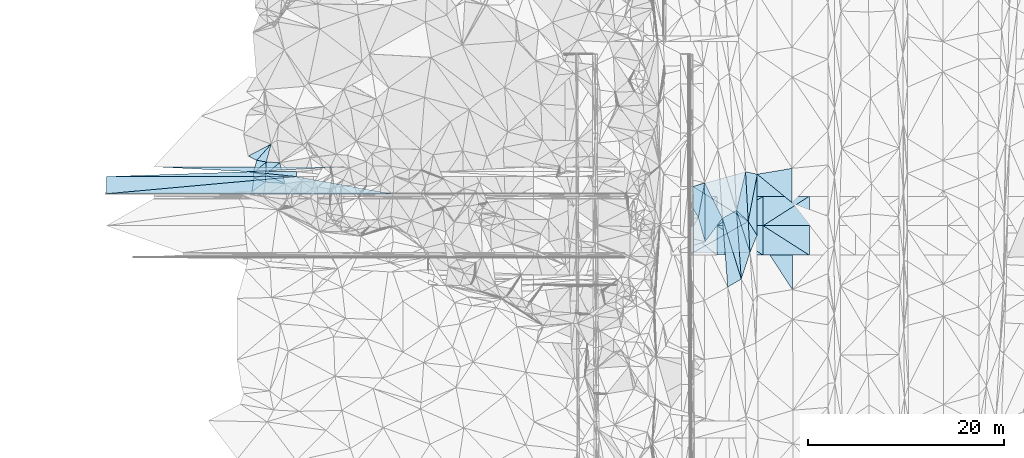
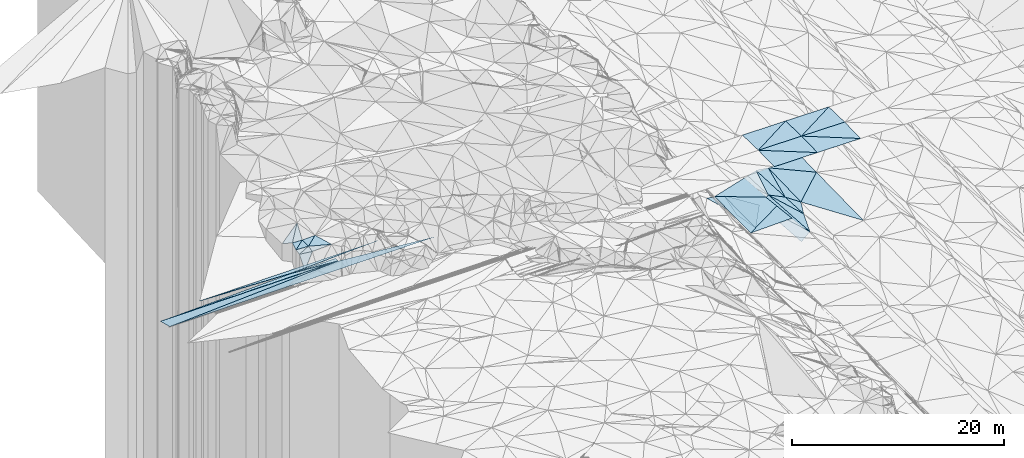
# One storey, part 66 of 275: 50 plates.
"""IFC2X3 building model written with IfcOpenShell, lengths in millimetres."""

from ifc_helpers import new_model, si_unit, frame, origin_with_axes, place, context, subcontext, project, spatial, polyline, outline, extrude, material, type_object, element, save


model = new_model("IFC2X3")

# Units and contexts
model_context = context("Model", 3, precision=1e-05, world=origin_with_axes())
body_context = subcontext(model_context, "Body", "Model", "MODEL_VIEW")
ifc_project = project(units=[si_unit("LENGTHUNIT", "METRE", prefix="MILLI"), si_unit("AREAUNIT", "SQUARE_METRE"), si_unit("VOLUMEUNIT", "CUBIC_METRE"), si_unit("MASSUNIT", "GRAM", prefix="KILO"), si_unit("TIMEUNIT", "SECOND"), si_unit("PLANEANGLEUNIT", "RADIAN"), si_unit("SOLIDANGLEUNIT", "STERADIAN"), si_unit("THERMODYNAMICTEMPERATUREUNIT", "DEGREE_CELSIUS"), si_unit("LUMINOUSINTENSITYUNIT", "LUMEN")], contexts=[model_context])

# Site, building, storey
site_placement = place(None, origin_with_axes())
site = spatial("IfcSite", under=ifc_project, at=site_placement, CompositionType="ELEMENT")
building_placement = place(site_placement, origin_with_axes())
building = spatial("IfcBuilding", under=site, at=building_placement, Name="Undefined", CompositionType="ELEMENT")
storey_placement = place(building_placement, origin_with_axes())
storey = spatial("IfcBuildingStorey", under=building, at=storey_placement, Name="Undefined", CompositionType="ELEMENT", Elevation=0.0)

# Plates
ifc_material = material()
plate_type_1 = type_object("IfcPlateType", PredefinedType="NOTDEFINED")
plate_1_placement = place(storey_placement, frame((-139112.719633925, 68794.8627842315, 48363.1850080399), z_axis=(0.00832550512650313, -4.76525014343269e-07, -0.999965342381505), x_axis=(-0.998627967401277, 0.0517015939893386, -0.00831431915169653)))
element("IfcPlate", 1, at=plate_1_placement, inside=storey, type_object=plate_type_1, material=ifc_material, Name="00_PR", context=body_context, shape_type="SweptSolid", body=[
    extrude(outline(polyline([(0.0, 0.0), (9681.6103515625, -4.99348971061409e-08), (-9629.9658203125, 998.66552734375), (0.0, 0.0)])), frame((-8.85201319254618e-08, 2.18876761149539e-07, -0.5000001331573), z_axis=(0.0, 0.0, 1.0), x_axis=(1.0, 0.0, 0.0)), (0.0, 0.0, 1.0), 1.0),
])
plate_2_placement = place(storey_placement, frame((-134278.571122702, 68294.5856908444, 48403.4330080909), z_axis=(0.00832550512650313, -4.76525014343269e-07, -0.999965342381505), x_axis=(-0.994653635901684, 0.102934762919728, -0.0082812541453832)))
element("IfcPlate", 2, at=plate_2_placement, inside=storey, type_object=plate_type_1, material=ifc_material, Name="00_PR", context=body_context, shape_type="SweptSolid", body=[
    extrude(outline(polyline([(0.0, 0.0), (4860.1328125, -2.46654963120818e-08), (51.4388885498047, 497.347015380859), (0.0, 0.0)])), frame((-8.85201319254618e-08, 2.18876761149539e-07, -0.5000001331573), z_axis=(0.0, 0.0, 1.0), x_axis=(1.0, 0.0, 0.0)), (0.0, 0.0, 1.0), 1.0),
])
plate_3_placement = place(storey_placement, frame((-139112.719633925, 68794.8627842315, 48363.1850080399), z_axis=(0.00832550512650313, -4.76525014343269e-07, -0.999965342381505), x_axis=(0.994653635899512, -0.102934762941165, 0.00828125413975662)))
element("IfcPlate", 3, at=plate_3_placement, inside=storey, type_object=plate_type_1, material=ifc_material, Name="00_PR", context=body_context, shape_type="SweptSolid", body=[
    extrude(outline(polyline([(0.0, 0.0), (4860.1328125, -2.46654963120818e-08), (-14374.642578125, 1989.38854980469), (0.0, 0.0)])), frame((-8.85201319254618e-08, 2.18876761149539e-07, -0.5000001331573), z_axis=(0.0, 0.0, 1.0), x_axis=(1.0, 0.0, 0.0)), (0.0, 0.0, 1.0), 1.0),
])
plate_4_placement = place(storey_placement, frame((-139112.719633925, 68794.8627842315, 48363.1850080399), z_axis=(0.00832550512650313, -4.76525014343269e-07, -0.999965342381505), x_axis=(-0.998627967401277, 0.0517015939893386, -0.00831431915169653)))
element("IfcPlate", 4, at=plate_4_placement, inside=storey, type_object=plate_type_1, material=ifc_material, Name="00_PR", context=body_context, shape_type="SweptSolid", body=[
    extrude(outline(polyline([(0.0, 0.0), (9681.6103515625, -4.99348971061409e-08), (-9629.9658203125, 998.66552734375), (0.0, 0.0)])), frame((-8.85201319254618e-08, 2.18876761149539e-07, -0.5000001331573), z_axis=(0.0, 0.0, 1.0), x_axis=(1.0, 0.0, 0.0)), (0.0, 0.0, 1.0), 1.0),
])
plate_5_placement = place(storey_placement, frame((-134278.571122702, 68294.5856908444, 48403.4330080909), z_axis=(0.00832550512650313, -4.76525014343269e-07, -0.999965342381505), x_axis=(-0.994653635901684, 0.102934762919728, -0.0082812541453832)))
element("IfcPlate", 5, at=plate_5_placement, inside=storey, type_object=plate_type_1, material=ifc_material, Name="00_PR", context=body_context, shape_type="SweptSolid", body=[
    extrude(outline(polyline([(0.0, 0.0), (4860.1328125, -2.46654963120818e-08), (51.4388885498047, 497.347015380859), (0.0, 0.0)])), frame((-8.85201319254618e-08, 2.18876761149539e-07, -0.5000001331573), z_axis=(0.0, 0.0, 1.0), x_axis=(1.0, 0.0, 0.0)), (0.0, 0.0, 1.0), 1.0),
])
plate_6_placement = place(storey_placement, frame((-139112.719633925, 68794.8627842315, 48363.1850080399), z_axis=(0.00832550512650313, -4.76525014343269e-07, -0.999965342381505), x_axis=(0.994653635899512, -0.102934762941165, 0.00828125413975662)))
element("IfcPlate", 6, at=plate_6_placement, inside=storey, type_object=plate_type_1, material=ifc_material, Name="00_PR", context=body_context, shape_type="SweptSolid", body=[
    extrude(outline(polyline([(0.0, 0.0), (4860.1328125, -2.46654963120818e-08), (-14374.642578125, 1989.38854980469), (0.0, 0.0)])), frame((-8.85201319254618e-08, 2.18876761149539e-07, -0.5000001331573), z_axis=(0.0, 0.0, 1.0), x_axis=(1.0, 0.0, 0.0)), (0.0, 0.0, 1.0), 1.0),
])
plate_7_placement = place(storey_placement, frame((-139112.719633925, 68794.8627842315, 48363.1850080399), z_axis=(0.00832550512650313, -4.76525014343269e-07, -0.999965342381505), x_axis=(-0.998627967401277, 0.0517015939893386, -0.00831431915169653)))
element("IfcPlate", 7, at=plate_7_placement, inside=storey, type_object=plate_type_1, material=ifc_material, Name="00_PR", context=body_context, shape_type="SweptSolid", body=[
    extrude(outline(polyline([(0.0, 0.0), (9681.6103515625, -4.99348971061409e-08), (-9629.9658203125, 998.66552734375), (0.0, 0.0)])), frame((-8.85201319254618e-08, 2.18876761149539e-07, -0.5000001331573), z_axis=(0.0, 0.0, 1.0), x_axis=(1.0, 0.0, 0.0)), (0.0, 0.0, 1.0), 1.0),
])
plate_8_placement = place(storey_placement, frame((-134278.571122702, 68294.5856908444, 48403.4330080909), z_axis=(0.00832550512650313, -4.76525014343269e-07, -0.999965342381505), x_axis=(-0.994653635901684, 0.102934762919728, -0.0082812541453832)))
element("IfcPlate", 8, at=plate_8_placement, inside=storey, type_object=plate_type_1, material=ifc_material, Name="00_PR", context=body_context, shape_type="SweptSolid", body=[
    extrude(outline(polyline([(0.0, 0.0), (4860.1328125, -2.46654963120818e-08), (51.4388885498047, 497.347015380859), (0.0, 0.0)])), frame((-8.85201319254618e-08, 2.18876761149539e-07, -0.5000001331573), z_axis=(0.0, 0.0, 1.0), x_axis=(1.0, 0.0, 0.0)), (0.0, 0.0, 1.0), 1.0),
])
plate_9_placement = place(storey_placement, frame((-139112.719633925, 68794.8627842315, 48363.1850080399), z_axis=(0.00832550512650313, -4.76525014343269e-07, -0.999965342381505), x_axis=(0.994653635899512, -0.102934762941165, 0.00828125413975662)))
element("IfcPlate", 9, at=plate_9_placement, inside=storey, type_object=plate_type_1, material=ifc_material, Name="00_PR", context=body_context, shape_type="SweptSolid", body=[
    extrude(outline(polyline([(0.0, 0.0), (4860.1328125, -2.46654963120818e-08), (-14374.642578125, 1989.38854980469), (0.0, 0.0)])), frame((-8.85201319254618e-08, 2.18876761149539e-07, -0.5000001331573), z_axis=(0.0, 0.0, 1.0), x_axis=(1.0, 0.0, 0.0)), (0.0, 0.0, 1.0), 1.0),
])
plate_type_2 = type_object("IfcPlateType", PredefinedType="NOTDEFINED")
plate_10_placement = place(storey_placement, frame((-88522.4950403435, 68786.3621235295, 42482.532308323), z_axis=(0.0289442363542971, 0.0198376266521223, -0.999384160246038), x_axis=(0.0544457940795084, -0.998350113550604, -0.0182402379520387)))
element("IfcPlate", 10, at=plate_10_placement, inside=storey, type_object=plate_type_2, material=ifc_material, Name="00_PR", context=body_context, shape_type="SweptSolid", body=[
    extrude(outline(polyline([(0.0, 0.0), (5058.21240234375, -1.88447302207351e-08), (1206.65393066406, 5428.92041015625), (0.0, 0.0)])), frame((-8.85201319254618e-08, 2.18876761149539e-07, -0.5000001331573), z_axis=(0.0, 0.0, 1.0), x_axis=(1.0, 0.0, 0.0)), (0.0, 0.0, 1.0), 1.0),
])
plate_type_3 = type_object("IfcPlateType", PredefinedType="NOTDEFINED")
plate_11_placement = place(storey_placement, frame((-88247.096599108, 63736.4952813632, 42390.2693112687), z_axis=(0.0290423405183576, 0.0199567936334746, -0.999378941565754), x_axis=(0.0556086531004329, -0.99828457589456, -0.0183189309560751)))
element("IfcPlate", 11, at=plate_11_placement, inside=storey, type_object=plate_type_3, material=ifc_material, Name="00_PR", context=body_context, shape_type="SweptSolid", body=[
    extrude(outline(polyline([(0.0, 0.0), (3174.69409179688, 7.49423634260893e-09), (2866.78857421875, 5777.74951171875), (0.0, 0.0)])), frame((-8.85201319254618e-08, 2.18876761149539e-07, -0.5000001331573), z_axis=(0.0, 0.0, 1.0), x_axis=(1.0, 0.0, 0.0)), (0.0, 0.0, 1.0), 1.0),
])
plate_type_4 = type_object("IfcPlateType", PredefinedType="NOTDEFINED")
plate_12_placement = place(storey_placement, frame((-93854.0467482746, 60556.6050504741, 42163.829311477), z_axis=(0.0290314678995804, 0.019975960311841, -0.999378874542191), x_axis=(-0.00316918011479654, 0.999797106622393, 0.0198922569582217)))
element("IfcPlate", 12, at=plate_12_placement, inside=storey, type_object=plate_type_4, material=ifc_material, Name="00_PR", context=body_context, shape_type="SweptSolid", body=[
    extrude(outline(polyline([(0.0, 0.0), (6733.9267578125, -4.21860022470355e-08), (3165.97998046875, 5619.38037109375), (0.0, 0.0)])), frame((-8.85201319254618e-08, 2.18876761149539e-07, -0.5000001331573), z_axis=(0.0, 0.0, 1.0), x_axis=(1.0, 0.0, 0.0)), (0.0, 0.0, 1.0), 1.0),
])
plate_type_5 = type_object("IfcPlateType", PredefinedType="NOTDEFINED")
plate_13_placement = place(storey_placement, frame((-88522.4986284358, 68786.3646997353, 42529.5002625876), z_axis=(0.0219721690891928, 0.0249481370511942, -0.999447254357723), x_axis=(0.97874614101186, -0.204417608322923, 0.0164144101912937)))
element("IfcPlate", 13, at=plate_13_placement, inside=storey, type_object=plate_type_5, material=ifc_material, Name="00", context=body_context, shape_type="SweptSolid", body=[
    extrude(outline(polyline([(0.0, 0.0), (1218.44165039063, 4.88216755911708e-09), (1299.85705566406, 4888.94384765625), (0.0, 0.0)])), frame((-8.85201319254618e-08, 2.18876761149539e-07, -0.5000001331573), z_axis=(0.0, 0.0, 1.0), x_axis=(1.0, 0.0, 0.0)), (0.0, 0.0, 1.0), 1.0),
])
plate_type_6 = type_object("IfcPlateType", PredefinedType="NOTDEFINED")
plate_14_placement = place(storey_placement, frame((-82030.6091164028, 60291.6034515764, 49069.4471609238), z_axis=(-0.00596425363183251, 0.0249920876322309, -0.999669857120038), x_axis=(-0.999982192348344, 5.74319826580448e-05, 0.00596755291272986)))
element("IfcPlate", 14, at=plate_14_placement, inside=storey, type_object=plate_type_6, material=ifc_material, Name="00_PR", context=body_context, shape_type="SweptSolid", body=[
    extrude(outline(polyline([(0.0, 0.0), (4700.08447265625, 2.85363057628274e-08), (4700.5322265625, 3000.93725585938), (0.0, 0.0)])), frame((-8.85201319254618e-08, 2.18876761149539e-07, -0.5000001331573), z_axis=(0.0, 0.0, 1.0), x_axis=(1.0, 0.0, 0.0)), (0.0, 0.0, 1.0), 1.0),
])
plate_15_placement = place(storey_placement, frame((-86730.6083517377, 60291.873384876, 49097.4951543896), z_axis=(-0.00335409582922735, 0.0249922421471594, -0.999682018380658), x_axis=(-0.999994365036816, 5.73239826033522e-05, 0.00335657691363734)))
element("IfcPlate", 15, at=plate_15_placement, inside=storey, type_object=plate_type_6, material=ifc_material, Name="00_PR", context=body_context, shape_type="SweptSolid", body=[
    extrude(outline(polyline([(0.0, 0.0), (4700.02587890625, 1.63781805895269e-08), (4700.27734375, 3000.93725585938), (0.0, 0.0)])), frame((-8.85201319254618e-08, 2.18876761149539e-07, -0.5000001331573), z_axis=(0.0, 0.0, 1.0), x_axis=(1.0, 0.0, 0.0)), (0.0, 0.0, 1.0), 1.0),
])
for number, where, z_axis, x_axis, name in (
    (16, (-82030.2653506532, 66291.5785032418, 49069.447160321), (-0.0059671242038211, -0.0249914044032891, -0.999669857070167), (-5.7277968073799e-05, -0.999687644772795, 0.0249921909375039), "00_PR"),
    (17, (-86730.4377731764, 63291.8484141642, 49172.4951599498), (-0.0059671242038211, -0.0249914044032891, -0.999669857070167), (5.72779774420735e-05, 0.999687644773175, -0.0249921909222736), "00_PR"),
):
    element("IfcPlate", number, at=place(storey_placement, frame(where, z_axis=z_axis, x_axis=x_axis)), inside=storey, type_object=plate_type_6, material=ifc_material, Name=name, context=body_context, shape_type="SweptSolid", body=[
        extrude(outline(polyline([(0.0, 0.0), (3000.9375, -1.02954800240695e-08), (3001.6376953125, 4700.083984375), (0.0, 0.0)])), frame((-8.85201319254618e-08, 2.18876761149539e-07, -0.5000001331573), z_axis=(0.0, 0.0, 1.0), x_axis=(1.0, 0.0, 0.0)), (0.0, 0.0, 1.0), 1.0),
    ])
for number, where, z_axis, x_axis, name in (
    (18, (-86730.2645858135, 66291.8484361537, 49097.4951539819), (-0.00335696192838307, -0.0249918579886119, -0.999682018364284), (-5.7277968073799e-05, -0.999687644772795, 0.0249921909375039), "00_PR"),
    (19, (-91430.4356898148, 63292.1178367168, 49188.2711537411), (-0.00335696192838307, -0.0249918579886119, -0.999682018364284), (5.72779774420735e-05, 0.999687644773175, -0.0249921909222736), "00_PR"),
):
    element("IfcPlate", number, at=place(storey_placement, frame(where, z_axis=z_axis, x_axis=x_axis)), inside=storey, type_object=plate_type_6, material=ifc_material, Name=name, context=body_context, shape_type="SweptSolid", body=[
        extrude(outline(polyline([(0.0, 0.0), (3000.9375, -1.02954800240695e-08), (3001.33154296875, 4700.02587890625), (0.0, 0.0)])), frame((-8.85201319254618e-08, 2.18876761149539e-07, -0.5000001331573), z_axis=(0.0, 0.0, 1.0), x_axis=(1.0, 0.0, 0.0)), (0.0, 0.0, 1.0), 1.0),
    ])
plate_16_placement = place(storey_placement, frame((-86730.4377729033, 63291.8734063981, 49172.4951603078), z_axis=(-0.00596425363183251, 0.0249920876322309, -0.999669857120038), x_axis=(0.999982192348352, -5.74309708544236e-05, -0.00596755292124954)))
element("IfcPlate", 20, at=plate_16_placement, inside=storey, type_object=plate_type_6, material=ifc_material, Name="00_PR", context=body_context, shape_type="SweptSolid", body=[
    extrude(outline(polyline([(0.0, 0.0), (4700.08447265625, 2.85363057628274e-08), (4700.5322265625, 3000.93725585938), (0.0, 0.0)])), frame((-8.85201319254618e-08, 2.18876761149539e-07, -0.5000001331573), z_axis=(0.0, 0.0, 1.0), x_axis=(1.0, 0.0, 0.0)), (0.0, 0.0, 1.0), 1.0),
])
plate_17_placement = place(storey_placement, frame((-91430.4356885064, 63292.142829059, 49188.2711536492), z_axis=(-0.00335409582922735, 0.0249922421471594, -0.999682018380658), x_axis=(0.99999436503679, -5.73239671697904e-05, -0.00335657692154193)))
element("IfcPlate", 21, at=plate_17_placement, inside=storey, type_object=plate_type_6, material=ifc_material, Name="00_PR", context=body_context, shape_type="SweptSolid", body=[
    extrude(outline(polyline([(0.0, 0.0), (4700.02587890625, 1.63781805895269e-08), (4700.27734375, 3000.93725585938), (0.0, 0.0)])), frame((-8.85201319254618e-08, 2.18876761149539e-07, -0.5000001331573), z_axis=(0.0, 0.0, 1.0), x_axis=(1.0, 0.0, 0.0)), (0.0, 0.0, 1.0), 1.0),
])
plate_type_7 = type_object("IfcPlateType", PredefinedType="NOTDEFINED")
for number, where, z_axis, x_axis, name in (
    (22, (-134278.571251839, 68294.4644289869, 48403.4479351075), (0.00806306952558709, -0.242528174049018, -0.970110855367713), (0.982635975767049, -0.177918113884165, 0.0526467841395968), "00_PR"),
    (23, (-134278.571251839, 68294.4644289869, 48403.4479351075), (0.00806306952558709, -0.242528174049018, -0.970110855367713), (0.982635975767049, -0.177918113884165, 0.0526467841395968), "00_PR"),
    (24, (-134278.571251839, 68294.4644289869, 48403.4479351075), (0.00806306952558709, -0.242528174049018, -0.970110855367713), (0.982635975767049, -0.177918113884165, 0.0526467841395968), "00_PR"),
):
    element("IfcPlate", number, at=place(storey_placement, frame(where, z_axis=z_axis, x_axis=x_axis)), inside=storey, type_object=plate_type_7, material=ifc_material, Name=name, context=body_context, shape_type="SweptSolid", body=[
        extrude(outline(polyline([(0.0, 0.0), (9839.1015625, 1.21508492156863e-07), (-18675.328125, 5317.83740234375), (0.0, 0.0)])), frame((-8.85201319254618e-08, 2.18876761149539e-07, -0.5000001331573), z_axis=(0.0, 0.0, 1.0), x_axis=(1.0, 0.0, 0.0)), (0.0, 0.0, 1.0), 1.0),
    ])
plate_type_8 = type_object("IfcPlateType", PredefinedType="NOTDEFINED")
for number, where, z_axis, x_axis, name in (
    (25, (-153615.280793758, 68295.5723766509, 48242.4559322076), (0.00806306952558709, -0.242528174049018, -0.970110855367713), (0.999965340787191, -5.73519775278889e-05, 0.0083254990906575), "00_PR"),
    (26, (-153615.280793758, 68295.5723766509, 48242.4559322076), (0.00806306952558709, -0.242528174049018, -0.970110855367713), (0.999965340787191, -5.73519775278889e-05, 0.0083254990906575), "00_PR"),
    (27, (-153615.280793758, 68295.5723766509, 48242.4559322076), (0.00806306952558709, -0.242528174049018, -0.970110855367713), (0.999965340787191, -5.73519775278889e-05, 0.0083254990906575), "00_PR"),
):
    element("IfcPlate", number, at=place(storey_placement, frame(where, z_axis=z_axis, x_axis=x_axis)), inside=storey, type_object=plate_type_8, material=ifc_material, Name=name, context=body_context, shape_type="SweptSolid", body=[
        extrude(outline(polyline([(0.0, 0.0), (19337.37890625, -2.38091161008924e-07), (3.6423819065094, 1803.85510253906), (0.0, 0.0)])), frame((-8.85201319254618e-08, 2.18876761149539e-07, -0.5000001331573), z_axis=(0.0, 0.0, 1.0), x_axis=(1.0, 0.0, 0.0)), (0.0, 0.0, 1.0), 1.0),
    ])
plate_type_9 = type_object("IfcPlateType", PredefinedType="NOTDEFINED")
plate_18_placement = place(storey_placement, frame((-138790.714361741, 66772.9794235328, 49779.6040655466), z_axis=(0.30232142071213, 0.530648794718268, -0.791841913037349), x_axis=(0.116457988768958, 0.803928779084959, 0.583211844024842)))
element("IfcPlate", 28, at=plate_18_placement, inside=storey, type_object=plate_type_9, material=ifc_material, Name="00", context=body_context, shape_type="SweptSolid", body=[
    extrude(outline(polyline([(0.0, 0.0), (1714.64282226563, -9.92440618574619e-09), (1614.68029785156, 1259.60607910156), (0.0, 0.0)])), frame((-8.85201319254618e-08, 2.18876761149539e-07, -0.5000001331573), z_axis=(0.0, 0.0, 1.0), x_axis=(1.0, 0.0, 0.0)), (0.0, 0.0, 1.0), 1.0),
])
plate_type_10 = type_object("IfcPlateType", PredefinedType="NOTDEFINED")
plate_19_placement = place(storey_placement, frame((-88247.100805461, 63736.4953708768, 42409.5001934469), z_axis=(0.020823257179428, 0.0200839539423721, -0.999581425775049), x_axis=(0.531044937620027, -0.847322682798328, -0.00596199996526825)))
element("IfcPlate", 29, at=plate_19_placement, inside=storey, type_object=plate_type_10, material=ifc_material, Name="00", context=body_context, shape_type="SweptSolid", body=[
    extrude(outline(polyline([(0.0, 0.0), (1677.28942871094, 4.14729584008455e-09), (2779.484375, 1534.06848144531), (0.0, 0.0)])), frame((-8.85201319254618e-08, 2.18876761149539e-07, -0.5000001331573), z_axis=(0.0, 0.0, 1.0), x_axis=(1.0, 0.0, 0.0)), (0.0, 0.0, 1.0), 1.0),
])
plate_type_11 = type_object("IfcPlateType", PredefinedType="NOTDEFINED")
plate_20_placement = place(storey_placement, frame((-87329.9510549763, 68537.2932915507, 42549.5003129866), z_axis=(0.0270381733028086, 0.0239773946825856, -0.999346797527607), x_axis=(-0.00424664732605177, -0.999700514395587, -0.0241007780722279)))
element("IfcPlate", 30, at=plate_20_placement, inside=storey, type_object=plate_type_11, material=ifc_material, Name="00", context=body_context, shape_type="SweptSolid", body=[
    extrude(outline(polyline([(0.0, 0.0), (6223.865234375, -2.41852831095457e-08), (4806.626953125, 897.070678710938), (0.0, 0.0)])), frame((-8.85201319254618e-08, 2.18876761149539e-07, -0.5000001331573), z_axis=(0.0, 0.0, 1.0), x_axis=(1.0, 0.0, 0.0)), (0.0, 0.0, 1.0), 1.0),
])
plate_type_12 = type_object("IfcPlateType", PredefinedType="NOTDEFINED")
plate_21_placement = place(storey_placement, frame((-137331.961066306, 69779.3048380143, 50999.502819114), z_axis=(0.0767516582066391, -0.0737901130182716, -0.994315946861601), x_axis=(-0.0575952518471251, -0.995920491142653, 0.0694633881036876)))
element("IfcPlate", 31, at=plate_21_placement, inside=storey, type_object=plate_type_12, material=ifc_material, Name="00", context=body_context, shape_type="SweptSolid", body=[
    extrude(outline(polyline([(0.0, 0.0), (1295.64660644531, 5.82076609134674e-11), (1162.58557128906, 1248.71728515625), (0.0, 0.0)])), frame((-8.85201319254618e-08, 2.18876761149539e-07, -0.5000001331573), z_axis=(0.0, 0.0, 1.0), x_axis=(1.0, 0.0, 0.0)), (0.0, 0.0, 1.0), 1.0),
])
plate_type_13 = type_object("IfcPlateType", PredefinedType="NOTDEFINED")
plate_22_placement = place(storey_placement, frame((-94942.9282150247, 66936.4179766867, 42689.5388403573), z_axis=(-0.385254115764943, 0.0309615710550885, -0.922290977622557), x_axis=(0.8869739761328, 0.288239815685894, -0.360825406972033)))
element("IfcPlate", 32, at=plate_22_placement, inside=storey, type_object=plate_type_13, material=ifc_material, Name="00", context=body_context, shape_type="SweptSolid", body=[
    extrude(outline(polyline([(0.0, 0.0), (2546.93823242188, 1.56578607857227e-08), (900.182800292969, 3214.1982421875), (0.0, 0.0)])), frame((-8.85201319254618e-08, 2.18876761149539e-07, -0.5000001331573), z_axis=(0.0, 0.0, 1.0), x_axis=(1.0, 0.0, 0.0)), (0.0, 0.0, 1.0), 1.0),
])
plate_type_14 = type_object("IfcPlateType", PredefinedType="NOTDEFINED")
plate_23_placement = place(storey_placement, frame((-138308.314253165, 69960.106657931, 50889.5316139814), z_axis=(0.190930764228914, 0.293336376406582, -0.93674927998244), x_axis=(-0.892983508714687, 0.44815597365132, -0.041673450112075)))
element("IfcPlate", 33, at=plate_23_placement, inside=storey, type_object=plate_type_14, material=ifc_material, Name="00", context=body_context, shape_type="SweptSolid", body=[
    extrude(outline(polyline([(0.0, 0.0), (959.84375, -5.99175109528005e-09), (-608.640747070313, 2286.6474609375), (0.0, 0.0)])), frame((-8.85201319254618e-08, 2.18876761149539e-07, -0.5000001331573), z_axis=(0.0, 0.0, 1.0), x_axis=(1.0, 0.0, 0.0)), (0.0, 0.0, 1.0), 1.0),
])
plate_type_15 = type_object("IfcPlateType", PredefinedType="NOTDEFINED")
plate_24_placement = place(storey_placement, frame((-137406.591141895, 68488.9442488027, 51089.5023134505), z_axis=(0.0627572610716591, -0.0730530342075252, -0.995351586313026), x_axis=(0.0575952518258283, 0.995920491149984, -0.0694633880162319)))
element("IfcPlate", 34, at=plate_24_placement, inside=storey, type_object=plate_type_15, material=ifc_material, Name="00", context=body_context, shape_type="SweptSolid", body=[
    extrude(outline(polyline([(0.0, 0.0), (1295.64660644531, 5.82076609134674e-11), (1316.94860839844, 1371.330078125), (0.0, 0.0)])), frame((-8.85201319254618e-08, 2.18876761149539e-07, -0.5000001331573), z_axis=(0.0, 0.0, 1.0), x_axis=(1.0, 0.0, 0.0)), (0.0, 0.0, 1.0), 1.0),
])
plate_type_16 = type_object("IfcPlateType", PredefinedType="NOTDEFINED")
plate_25_placement = place(storey_placement, frame((-138641.866612058, 68686.3055278942, 50979.5044656755), z_axis=(0.0941343586142169, -0.0946825748713205, -0.991046887157226), x_axis=(0.252727053869748, 0.965130875255914, -0.0682013919951183)))
element("IfcPlate", 35, at=plate_25_placement, inside=storey, type_object=plate_type_16, material=ifc_material, Name="00", context=body_context, shape_type="SweptSolid", body=[
    extrude(outline(polyline([(0.0, 0.0), (1319.62121582031, -3.82715370506048e-09), (1384.56408691406, 996.9365234375), (0.0, 0.0)])), frame((-8.85201319254618e-08, 2.18876761149539e-07, -0.5000001331573), z_axis=(0.0, 0.0, 1.0), x_axis=(1.0, 0.0, 0.0)), (0.0, 0.0, 1.0), 1.0),
])
plate_type_17 = type_object("IfcPlateType", PredefinedType="NOTDEFINED")
plate_26_placement = place(storey_placement, frame((-137411.095122285, 67732.6453520249, 50949.5116568715), z_axis=(0.117066298901315, 0.180060821347724, -0.97666451879708), x_axis=(0.0058900617754013, 0.983283280783507, 0.181987078947667)))
element("IfcPlate", 36, at=plate_26_placement, inside=storey, type_object=plate_type_17, material=ifc_material, Name="00", context=body_context, shape_type="SweptSolid", body=[
    extrude(outline(polyline([(0.0, 0.0), (769.285400390625, 1.74622982740402e-10), (-104.642570495605, 2008.29528808594), (0.0, 0.0)])), frame((-8.85201319254618e-08, 2.18876761149539e-07, -0.5000001331573), z_axis=(0.0, 0.0, 1.0), x_axis=(1.0, 0.0, 0.0)), (0.0, 0.0, 1.0), 1.0),
])
plate_27_placement = place(storey_placement, frame((-92683.8349906146, 67670.5419548204, 41770.5289000602), z_axis=(-0.334487683884291, 0.0209477943368486, -0.942167277739014), x_axis=(0.0063575985768661, -0.999680016381462, -0.0244835820070246)))
element("IfcPlate", 37, at=plate_27_placement, inside=storey, type_object=plate_type_17, material=ifc_material, Name="00", context=body_context, shape_type="SweptSolid", body=[
    extrude(outline(polyline([(0.0, 0.0), (6004.0234375, -1.3169483281672e-08), (3541.96704101563, 705.22607421875), (0.0, 0.0)])), frame((-8.85201319254618e-08, 2.18876761149539e-07, -0.5000001331573), z_axis=(0.0, 0.0, 1.0), x_axis=(1.0, 0.0, 0.0)), (0.0, 0.0, 1.0), 1.0),
])
plate_type_18 = type_object("IfcPlateType", PredefinedType="NOTDEFINED")
plate_28_placement = place(storey_placement, frame((-88070.5558919204, 60567.2487890095, 42349.5003404291), z_axis=(0.0297350551247534, 0.0231126740516216, -0.999290563747558), x_axis=(-0.310398817463177, -0.950093912545755, -0.0312110791380441)))
element("IfcPlate", 38, at=plate_28_placement, inside=storey, type_object=plate_type_18, material=ifc_material, Name="00", context=body_context, shape_type="SweptSolid", body=[
    extrude(outline(polyline([(0.0, 0.0), (2851.55151367188, 8.81846062839031e-09), (-3637.40307617188, 2634.50244140625), (0.0, 0.0)])), frame((-8.85201319254618e-08, 2.18876761149539e-07, -0.5000001331573), z_axis=(0.0, 0.0, 1.0), x_axis=(1.0, 0.0, 0.0)), (0.0, 0.0, 1.0), 1.0),
])
plate_type_19 = type_object("IfcPlateType", PredefinedType="NOTDEFINED")
plate_29_placement = place(storey_placement, frame((-137406.552801046, 68489.1598799247, 51089.5383918135), z_axis=(0.13943990071647, 0.358207179282961, -0.923170694291324), x_axis=(-0.932579198289818, -0.265955606285574, -0.244056662278236)))
element("IfcPlate", 39, at=plate_29_placement, inside=storey, type_object=plate_type_19, material=ifc_material, Name="00", context=body_context, shape_type="SweptSolid", body=[
    extrude(outline(polyline([(0.0, 0.0), (1270.19677734375, 1.32131390273571e-08), (1126.36083984375, 555.2578125), (0.0, 0.0)])), frame((-8.85201319254618e-08, 2.18876761149539e-07, -0.5000001331573), z_axis=(0.0, 0.0, 1.0), x_axis=(1.0, 0.0, 0.0)), (0.0, 0.0, 1.0), 1.0),
])
plate_type_20 = type_object("IfcPlateType", PredefinedType="NOTDEFINED")
plate_30_placement = place(storey_placement, frame((-138591.080864217, 68151.2533512376, 50779.5183233219), z_axis=(0.201601364107437, 0.177085784408501, -0.963326276476691), x_axis=(0.932579198300862, 0.265955606292563, 0.244056662228418)))
element("IfcPlate", 40, at=plate_30_placement, inside=storey, type_object=plate_type_20, material=ifc_material, Name="00", context=body_context, shape_type="SweptSolid", body=[
    extrude(outline(polyline([(0.0, 0.0), (1270.19677734375, 1.32131390273571e-08), (1030.62768554688, 731.031188964844), (0.0, 0.0)])), frame((-8.85201319254618e-08, 2.18876761149539e-07, -0.5000001331573), z_axis=(0.0, 0.0, 1.0), x_axis=(1.0, 0.0, 0.0)), (0.0, 0.0, 1.0), 1.0),
])
plate_type_21 = type_object("IfcPlateType", PredefinedType="NOTDEFINED")
plate_31_placement = place(storey_placement, frame((-89444.6645766849, 64842.7330187322, 42407.5001864334), z_axis=(0.0201893616458324, 0.020048903433415, -0.999595133615331), x_axis=(0.734559968439947, -0.678542664710451, 0.00122675716589199)))
element("IfcPlate", 41, at=plate_31_placement, inside=storey, type_object=plate_type_21, material=ifc_material, Name="00", context=body_context, shape_type="SweptSolid", body=[
    extrude(outline(polyline([(0.0, 0.0), (1630.31408691406, 7.1358954301104e-09), (3910.39013671875, 2209.10693359375), (0.0, 0.0)])), frame((-8.85201319254618e-08, 2.18876761149539e-07, -0.5000001331573), z_axis=(0.0, 0.0, 1.0), x_axis=(1.0, 0.0, 0.0)), (0.0, 0.0, 1.0), 1.0),
])
plate_type_22 = type_object("IfcPlateType", PredefinedType="NOTDEFINED")
plate_32_placement = place(storey_placement, frame((-137331.917544982, 69779.4998987367, 50999.5327756582), z_axis=(0.163783332971017, 0.316332404705812, -0.934402926779419), x_axis=(-0.977339198298451, 0.180790092876304, -0.110104649252967)))
element("IfcPlate", 42, at=plate_32_placement, inside=storey, type_object=plate_type_22, material=ifc_material, Name="00", context=body_context, shape_type="SweptSolid", body=[
    extrude(outline(polyline([(0.0, 0.0), (999.049560546875, -1.00262695923448e-08), (-233.521957397461, 2019.89294433594), (0.0, 0.0)])), frame((-8.85201319254618e-08, 2.18876761149539e-07, -0.5000001331573), z_axis=(0.0, 0.0, 1.0), x_axis=(1.0, 0.0, 0.0)), (0.0, 0.0, 1.0), 1.0),
])
plate_type_23 = type_object("IfcPlateType", PredefinedType="NOTDEFINED")
plate_33_placement = place(storey_placement, frame((-135964.415016162, 69727.9067220559, 51089.5002865167), z_axis=(0.0229151861006315, -0.0266745848892539, -0.999381489105617), x_axis=(0.246207785131265, -0.968705012826703, 0.0315011851391935)))
element("IfcPlate", 43, at=plate_33_placement, inside=storey, type_object=plate_type_23, material=ifc_material, Name="00", context=body_context, shape_type="SweptSolid", body=[
    extrude(outline(polyline([(0.0, 0.0), (2222.138671875, -3.43425199389458e-09), (845.086791992188, 1703.15246582031), (0.0, 0.0)])), frame((-8.85201319254618e-08, 2.18876761149539e-07, -0.5000001331573), z_axis=(0.0, 0.0, 1.0), x_axis=(1.0, 0.0, 0.0)), (0.0, 0.0, 1.0), 1.0),
])
plate_type_24 = type_object("IfcPlateType", PredefinedType="NOTDEFINED")
plate_34_placement = place(storey_placement, frame((-89444.6622506853, 64842.7355362258, 42407.5002978101), z_axis=(0.0248584469080261, 0.0251038427647973, -0.99937573249292), x_axis=(0.227591147411704, 0.973291156415634, 0.0301097071215)))
element("IfcPlate", 44, at=plate_34_placement, inside=storey, type_object=plate_type_24, material=ifc_material, Name="00", context=body_context, shape_type="SweptSolid", body=[
    extrude(outline(polyline([(0.0, 0.0), (4051.84936523438, -7.23230186849833e-09), (-804.076293945313, 1418.23315429688), (0.0, 0.0)])), frame((-8.85201319254618e-08, 2.18876761149539e-07, -0.5000001331573), z_axis=(0.0, 0.0, 1.0), x_axis=(1.0, 0.0, 0.0)), (0.0, 0.0, 1.0), 1.0),
])
plate_type_25 = type_object("IfcPlateType", PredefinedType="NOTDEFINED")
plate_35_placement = place(storey_placement, frame((-90872.3323681754, 64050.8273579887, 42226.5032283031), z_axis=(0.110081117759986, 0.0286158833934665, -0.993510583099306), x_axis=(0.869160661522314, 0.482097659363617, 0.110188889177696)))
element("IfcPlate", 45, at=plate_35_placement, inside=storey, type_object=plate_type_25, material=ifc_material, Name="00", context=body_context, shape_type="SweptSolid", body=[
    extrude(outline(polyline([(0.0, 0.0), (1642.63391113281, -5.03496266901493e-09), (-1315.87756347656, 6347.78271484375), (0.0, 0.0)])), frame((-8.85201319254618e-08, 2.18876761149539e-07, -0.5000001331573), z_axis=(0.0, 0.0, 1.0), x_axis=(1.0, 0.0, 0.0)), (0.0, 0.0, 1.0), 1.0),
])
plate_type_26 = type_object("IfcPlateType", PredefinedType="NOTDEFINED")
plate_36_placement = place(storey_placement, frame((-87329.9512538439, 68537.2941478482, 42549.5003274034), z_axis=(0.0266311808160418, 0.0256797324695797, -0.999315431457272), x_axis=(0.985699891149709, 0.165722146673856, 0.0305269502122504)))
element("IfcPlate", 46, at=plate_36_placement, inside=storey, type_object=plate_type_26, material=ifc_material, Name="00", context=body_context, shape_type="SweptSolid", body=[
    extrude(outline(polyline([(0.0, 0.0), (3603.37353515625, -2.55968188866973e-08), (3030.29931640625, 3469.32080078125), (0.0, 0.0)])), frame((-8.85201319254618e-08, 2.18876761149539e-07, -0.5000001331573), z_axis=(0.0, 0.0, 1.0), x_axis=(1.0, 0.0, 0.0)), (0.0, 0.0, 1.0), 1.0),
])
plate_type_27 = type_object("IfcPlateType", PredefinedType="NOTDEFINED")
plate_37_placement = place(storey_placement, frame((-87356.3818959368, 62315.2912376515, 42399.5002883776), z_axis=(0.0264657679046294, 0.0226595188652712, -0.999392870363809), x_axis=(0.735424739610759, 0.676711247508546, 0.034818671196298)))
element("IfcPlate", 47, at=plate_37_placement, inside=storey, type_object=plate_type_27, material=ifc_material, Name="00", context=body_context, shape_type="SweptSolid", body=[
    extrude(outline(polyline([(0.0, 0.0), (4882.43798828125, 2.11730366572738e-08), (-1094.59655761719, 6514.35009765625), (0.0, 0.0)])), frame((-8.85201319254618e-08, 2.18876761149539e-07, -0.5000001331573), z_axis=(0.0, 0.0, 1.0), x_axis=(1.0, 0.0, 0.0)), (0.0, 0.0, 1.0), 1.0),
])
plate_type_28 = type_object("IfcPlateType", PredefinedType="NOTDEFINED")
plate_38_placement = place(storey_placement, frame((-83765.7168761619, 65619.2925555585, 42569.5002889728), z_axis=(0.0252450908704608, 0.0239861374411795, -0.99939349137244), x_axis=(-0.735424739608236, -0.67671124751135, -0.0348186711950742)))
element("IfcPlate", 48, at=plate_38_placement, inside=storey, type_object=plate_type_28, material=ifc_material, Name="00", context=body_context, shape_type="SweptSolid", body=[
    extrude(outline(polyline([(0.0, 0.0), (4882.43798828125, 2.11730366572738e-08), (647.279113769531, 4560.69384765625), (0.0, 0.0)])), frame((-8.85201319254618e-08, 2.18876761149539e-07, -0.5000001331573), z_axis=(0.0, 0.0, 1.0), x_axis=(1.0, 0.0, 0.0)), (0.0, 0.0, 1.0), 1.0),
])
plate_type_29 = type_object("IfcPlateType", PredefinedType="NOTDEFINED")
plate_39_placement = place(storey_placement, frame((-92645.350942559, 61668.4418171322, 41623.5218331381), z_axis=(0.291263847777436, 0.0252736918987842, -0.956308847326892), x_axis=(-0.00635759854524865, 0.999680016380923, 0.0244835820372434)))
element("IfcPlate", 49, at=plate_39_placement, inside=storey, type_object=plate_type_29, material=ifc_material, Name="00", context=body_context, shape_type="SweptSolid", body=[
    extrude(outline(polyline([(0.0, 0.0), (6004.0234375, -1.3169483281672e-08), (2385.1123046875, 1869.36267089844), (0.0, 0.0)])), frame((-8.85201319254618e-08, 2.18876761149539e-07, -0.5000001331573), z_axis=(0.0, 0.0, 1.0), x_axis=(1.0, 0.0, 0.0)), (0.0, 0.0, 1.0), 1.0),
])
plate_type_30 = type_object("IfcPlateType", PredefinedType="NOTDEFINED")
plate_40_placement = place(storey_placement, frame((-88955.6227926066, 57858.0132727143, 42260.5047013201), z_axis=(0.13235665359372, 0.0355264092271672, -0.99056528835655), x_axis=(-0.855591399679379, -0.500467529448063, -0.132270967195501)))
element("IfcPlate", 50, at=plate_40_placement, inside=storey, type_object=plate_type_30, material=ifc_material, Name="00", context=body_context, shape_type="SweptSolid", body=[
    extrude(outline(polyline([(0.0, 0.0), (1610.33068847656, -7.08678271621466e-09), (-1454.89624023438, 6317.369140625), (0.0, 0.0)])), frame((-8.85201319254618e-08, 2.18876761149539e-07, -0.5000001331573), z_axis=(0.0, 0.0, 1.0), x_axis=(1.0, 0.0, 0.0)), (0.0, 0.0, 1.0), 1.0),
])

save(model, "model.ifc")
